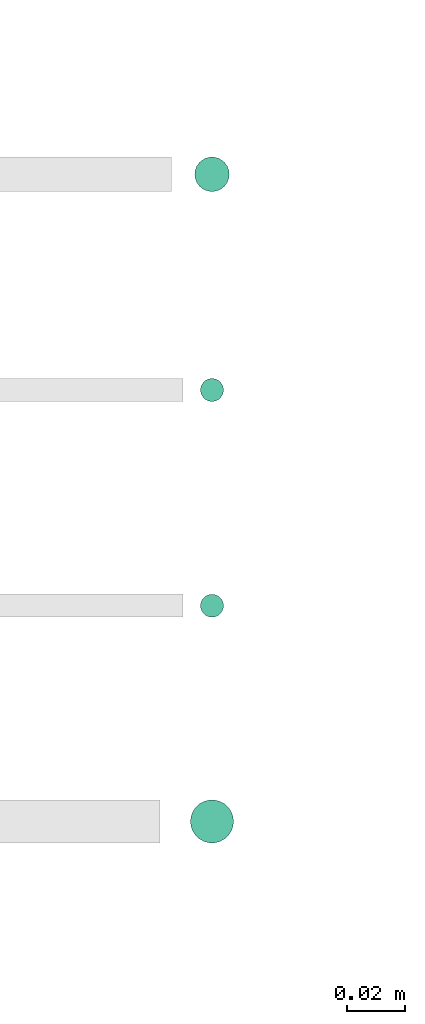
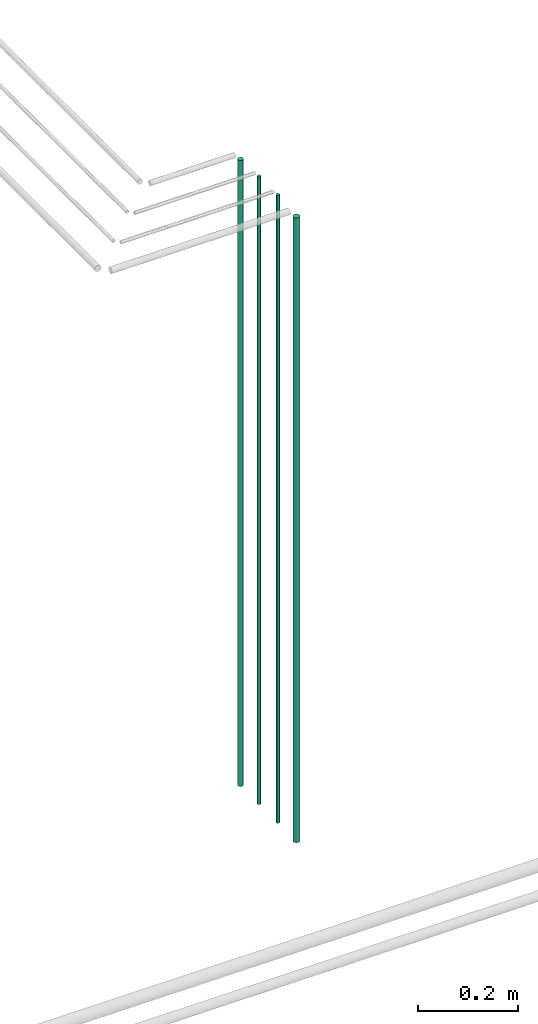
# One storey, part 15 of 331: 4 flow segments.
"""IFC2X3 building model written with IfcOpenShell, lengths in millimetres."""

from ifc_helpers import new_model, entity, si_unit, converted_unit, derived_unit, direction, frame, origin, origin_2d_with_axis, place, context, subcontext, project, spatial, circle, extrude, type_object, element, save


model = new_model("IFC2X3")

# Units and contexts
model_context = context("Model", 3, precision=0.01, world=origin(), true_north=direction((6.12303176911189e-17, 1.0)))
body_context = subcontext(model_context, "Body", "Model", "MODEL_VIEW")
ifc_project = project(units=[si_unit("LENGTHUNIT", "METRE", prefix="MILLI"), si_unit("AREAUNIT", "SQUARE_METRE"), si_unit("VOLUMEUNIT", "CUBIC_METRE"), converted_unit("PLANEANGLEUNIT", "DEGREE", entity("IfcRatioMeasure", 0.0174532925199433), si_unit("PLANEANGLEUNIT", "RADIAN"), dimensions=[0, 0, 0, 0, 0, 0, 0]), si_unit("MASSUNIT", "GRAM", prefix="KILO"), derived_unit("MASSDENSITYUNIT", [(si_unit("MASSUNIT", "GRAM", prefix="KILO"), 1), (si_unit("LENGTHUNIT", "METRE"), -3)]), derived_unit("MOMENTOFINERTIAUNIT", [(si_unit("LENGTHUNIT", "METRE"), 4)]), si_unit("TIMEUNIT", "SECOND"), si_unit("FREQUENCYUNIT", "HERTZ"), si_unit("THERMODYNAMICTEMPERATUREUNIT", "DEGREE_CELSIUS"), derived_unit("THERMALTRANSMITTANCEUNIT", [(si_unit("MASSUNIT", "GRAM", prefix="KILO"), 1), (si_unit("THERMODYNAMICTEMPERATUREUNIT", "KELVIN"), -1), (si_unit("TIMEUNIT", "SECOND"), -3)]), derived_unit("VOLUMETRICFLOWRATEUNIT", [(si_unit("LENGTHUNIT", "METRE"), 3), (si_unit("TIMEUNIT", "SECOND"), -1)]), derived_unit("MASSFLOWRATEUNIT", [(si_unit("MASSUNIT", "GRAM", prefix="KILO"), 1), (si_unit("TIMEUNIT", "SECOND"), -1)]), derived_unit("ROTATIONALFREQUENCYUNIT", [(si_unit("TIMEUNIT", "SECOND"), -1)]), si_unit("ELECTRICCURRENTUNIT", "AMPERE"), si_unit("ELECTRICVOLTAGEUNIT", "VOLT"), si_unit("POWERUNIT", "WATT"), si_unit("FORCEUNIT", "NEWTON", prefix="KILO"), si_unit("ILLUMINANCEUNIT", "LUX"), si_unit("LUMINOUSFLUXUNIT", "LUMEN"), si_unit("LUMINOUSINTENSITYUNIT", "CANDELA"), derived_unit("USERDEFINED", [(si_unit("MASSUNIT", "GRAM", prefix="KILO"), -1), (si_unit("LENGTHUNIT", "METRE"), -2), (si_unit("TIMEUNIT", "SECOND"), 3), (si_unit("LUMINOUSFLUXUNIT", "LUMEN"), 1)]), derived_unit("LINEARVELOCITYUNIT", [(si_unit("LENGTHUNIT", "METRE"), 1), (si_unit("TIMEUNIT", "SECOND"), -1)]), si_unit("PRESSUREUNIT", "PASCAL"), derived_unit("USERDEFINED", [(si_unit("LENGTHUNIT", "METRE"), -2), (si_unit("MASSUNIT", "GRAM", prefix="KILO"), 1), (si_unit("TIMEUNIT", "SECOND"), -2)]), derived_unit("LINEARFORCEUNIT", [(si_unit("MASSUNIT", "GRAM", prefix="KILO"), 1), (si_unit("LENGTHUNIT", "METRE"), 1), (si_unit("TIMEUNIT", "SECOND"), -2), (si_unit("LENGTHUNIT", "METRE"), -1)]), derived_unit("PLANARFORCEUNIT", [(si_unit("MASSUNIT", "GRAM", prefix="KILO"), 1), (si_unit("LENGTHUNIT", "METRE"), 1), (si_unit("TIMEUNIT", "SECOND"), -2), (si_unit("LENGTHUNIT", "METRE"), -2)])], contexts=[model_context])

# Site, building, storey
site_placement = place(None, frame((0.0, -0.00077364408347762, 0.0)))
site = spatial("IfcSite", under=ifc_project, at=site_placement, CompositionType="ELEMENT")
building_placement = place(site_placement, origin())
building = spatial("IfcBuilding", under=site, at=building_placement, CompositionType="ELEMENT")
storey_placement = place(building_placement, origin())
storey = spatial("IfcBuildingStorey", under=building, at=storey_placement, CompositionType="ELEMENT", Elevation=0.0)

# Flow segments
pipe_segment_type = type_object("IfcPipeSegmentType", PredefinedType="NOTDEFINED")
flow_segment_1_placement = place(storey_placement, frame((27888.4792537101, 4927.40472776444, 5700.0)))
element("IfcFlowSegment", 1, at=flow_segment_1_placement, inside=storey, type_object=pipe_segment_type, context=body_context, shape_type="SweptSolid", body=[
    extrude(circle(Radius=6.0, at=origin_2d_with_axis()), frame((7.59527223591454, 7.59527223591562, 0.0)), (0.0, 0.0, 1.0), 1536.0),
])
for number, where in (
    (2, (27890.4792537101, 4854.40472776444, 5700.0)),
    (3, (27890.4792537101, 4779.40472776444, 5700.0)),
):
    element("IfcFlowSegment", number, at=place(storey_placement, frame(where)), inside=storey, type_object=pipe_segment_type, context=body_context, shape_type="SweptSolid", body=[
        extrude(circle(Radius=4.0, at=origin_2d_with_axis()), frame((5.59527223591499, 5.59527223591607, 0.0)), (0.0, 0.0, 1.0), 1540.0),
    ])
flow_segment_2_placement = place(storey_placement, frame((27886.9792537101, 4700.90472776444, 5700.0)))
element("IfcFlowSegment", 4, at=flow_segment_2_placement, inside=storey, type_object=pipe_segment_type, context=body_context, shape_type="SweptSolid", body=[
    extrude(circle(Radius=7.5, at=origin_2d_with_axis()), frame((9.09527223591419, 9.09527223591582, 0.0)), (0.0, 0.0, 1.0), 1532.0),
])

save(model, "model.ifc")
